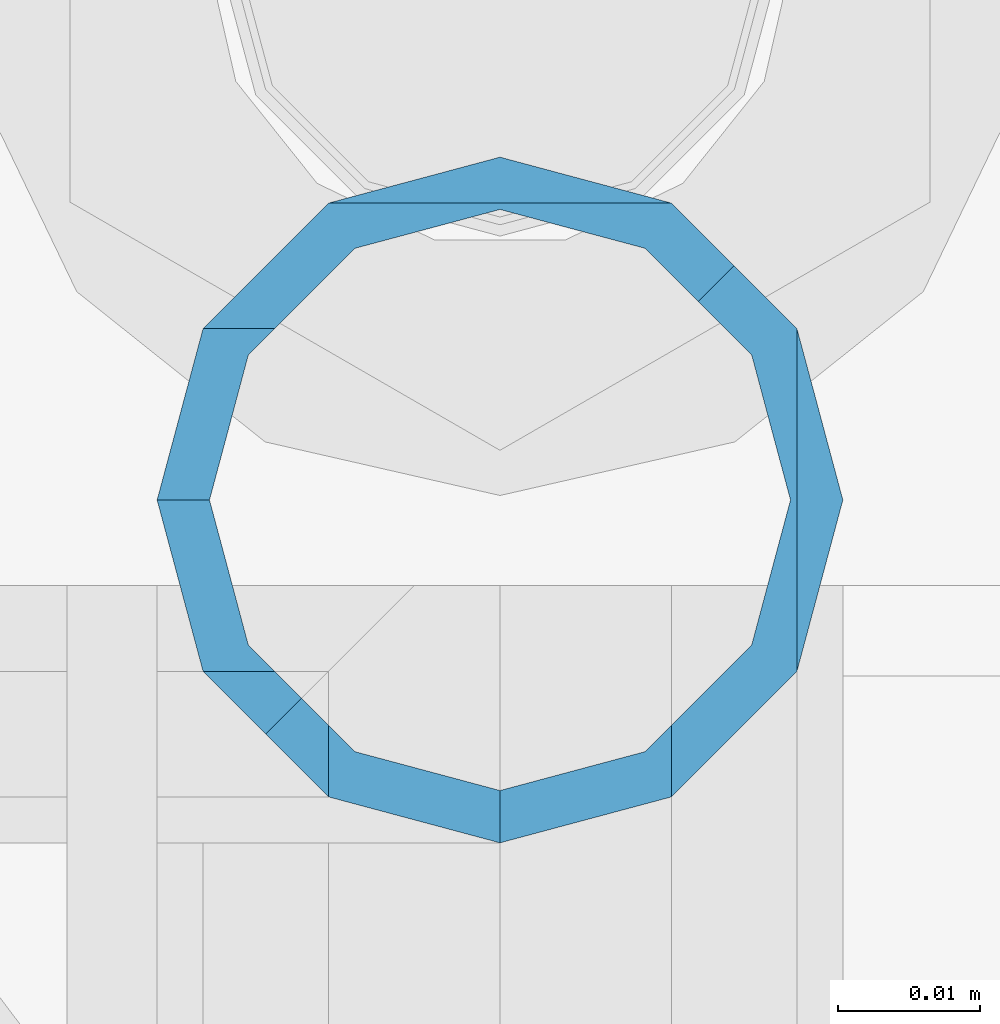
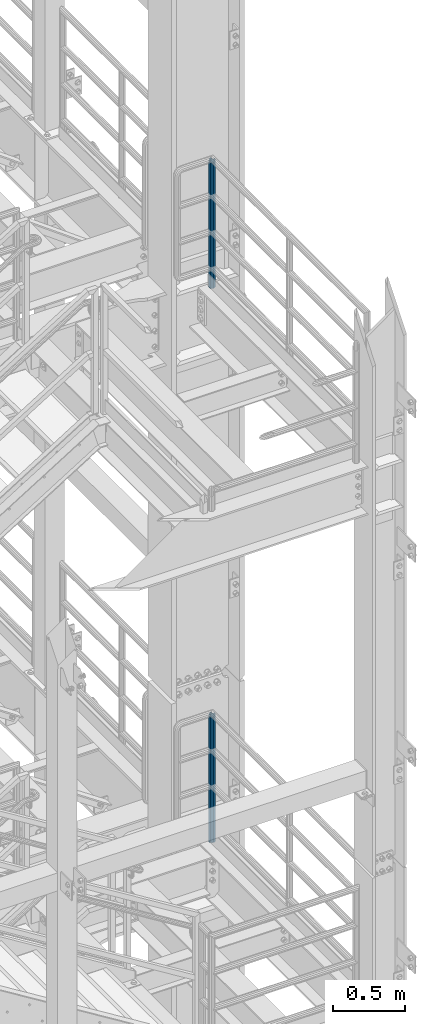
# One storey, part 664 of 1876: 2 columns, 2 elements without a shape of their own.
"""IFC2X3 building model written with IfcOpenShell, lengths in millimetres."""

from ifc_helpers import new_model, si_unit, frame, origin_with_axes, place, context, subcontext, project, spatial, faceted_brep, material, type_object, element, aggregate, save


model = new_model("IFC2X3")

# Units and contexts
model_context = context("Model", 3, precision=1e-05, world=origin_with_axes())
body_context = subcontext(model_context, "Body", "Model", "MODEL_VIEW")
ifc_project = project(units=[si_unit("LENGTHUNIT", "METRE", prefix="MILLI"), si_unit("AREAUNIT", "SQUARE_METRE"), si_unit("VOLUMEUNIT", "CUBIC_METRE"), si_unit("MASSUNIT", "GRAM", prefix="KILO"), si_unit("TIMEUNIT", "SECOND"), si_unit("PLANEANGLEUNIT", "RADIAN"), si_unit("SOLIDANGLEUNIT", "STERADIAN"), si_unit("THERMODYNAMICTEMPERATUREUNIT", "DEGREE_CELSIUS"), si_unit("LUMINOUSINTENSITYUNIT", "LUMEN")], contexts=[model_context])

# Site, building, storey
site_placement = place(None, origin_with_axes())
site = spatial("IfcSite", under=ifc_project, at=site_placement, CompositionType="ELEMENT")
building_placement = place(site_placement, origin_with_axes())
building = spatial("IfcBuilding", under=site, at=building_placement, Name="Undefined", CompositionType="ELEMENT")
storey_placement = place(building_placement, origin_with_axes())
storey = spatial("IfcBuildingStorey", under=building, at=storey_placement, Name="Undefined", CompositionType="ELEMENT", Elevation=0.0)

# Assembly, column
assembly_1_placement = place(storey_placement, origin_with_axes())
assembly_1 = element("IfcElementAssembly", 1, at=assembly_1_placement, inside=storey, Name="RAIL", AssemblyPlace="NOTDEFINED", PredefinedType="RIGID_FRAME")
ifc_material = material()
column_type = type_object("IfcColumnType", Name="PIPE1-1/2SCH40", PredefinedType="NOTDEFINED")
column_1_placement = place(assembly_1_placement, frame((7620.00000000001, -4788.2175, 17983.2), z_axis=(0.0, 1.0, 0.0), x_axis=(0.0, 0.0, 1.0)))
column_1 = element("IfcColumn", 2, at=column_1_placement, type_object=column_type, material=ifc_material, Name="POST", ObjectType="PIPE1-1/2SCH40", context=body_context, shape_type="Brep", body=[
    faceted_brep([(1076.325, 24.1300000000001, 0.0), (1064.26, 20.8971929933184, 12.0649999999996), (1064.25999999999, 20.8971929933186, -12.0649999999996), (1059.84389372958, 16.4810867391689, 16.4811062541503), (1057.32835795224, 13.9655509593422, 13.9655704718371), (1061.07042843786, 17.7076214311803, 10.2235000000001), (1063.80980700668, 20.4469999999999, 0.0), (1061.07042843786, 17.7076214311803, -10.2235000000001), (1055.42780700668, 12.0650000000001, -15.8661214311805), (1055.42780700667, 12.0649999999996, -20.8971929933186), (1054.93437856882, 10.2235000000001, -17.7076214311801), (1052.195, 0.0, -20.4470000000001), (1052.19499999999, 0.0, -24.1300000000001), (1055.42780700668, -12.0650000000001, -15.8661214311805), (1055.42780700667, -12.0649999999996, -20.8971929933186), (1054.93437856882, -10.2235000000001, -17.7076214311801), (1057.32837749231, -13.9655704718352, -13.9655509593449), (1059.84391327711, -16.4811062541476, -16.4810867391716), (1055.42780700668, -15.8661214311742, -12.065000000006), (1055.42780700668, -20.8971929933184, -12.0649999999996), (1054.93437856882, -17.7076214311801, -10.2235000000001), (1052.195, -20.4470000000001, 0.0), (1052.195, -24.1300000000001, 0.0), (1054.93437856882, -17.7076214311801, 10.2235000000001), (1055.42780700668, -15.8661214311869, 12.0649999999932), (1055.42780700668, -20.8971929933184, 12.0649999999996), (1076.325, 0.0, 24.1300000000001), (1064.26, -12.0650000000001, 20.8971929933186), (1064.26, 12.065, 20.8971929933186), (1061.07042843787, -10.2235000000001, 17.7076214311801), (1063.80980700669, 0.0, 20.4470000000001), (1061.07042843787, 10.2235000000001, 17.7076214311801), (0.0, -20.8971929933184, -12.0649999999996), (0.0, -12.0650000000001, -20.8971929933186), (-1.45519152283669e-11, 0.0, -24.130000000001), (0.0, 12.0650000000001, -20.8971929933186), (0.0, 20.8971929933184, -12.0649999999996), (0.0, 24.1299999999992, 0.0), (0.0, 20.8971929933184, 12.0649999999996), (0.0, 12.0650000000001, 20.8971929933186), (-1.45519152283669e-11, 0.0, 24.130000000001), (0.0, -20.8971929933184, 12.0649999999996), (0.0, -24.1299999999992, 0.0), (0.0, -12.0650000000001, 20.8971929933186), (0.0, -17.7076214311803, -10.2235000000001), (0.0, -10.2235000000001, -17.7076214311801), (-1.45519152283669e-11, 0.0, -20.4470000000001), (0.0, 10.2235000000001, -17.7076214311801), (0.0, 17.7076214311803, -10.2235000000001), (0.0, 20.4469999999999, 0.0), (0.0, 17.7076214311803, 10.2235000000001), (0.0, 10.2235000000001, 17.7076214311801), (-1.45519152283669e-11, 0.0, 20.4470000000001), (0.0, -10.2235000000001, 17.7076214311801), (0.0, -17.7076214311803, 10.2235000000001), (0.0, -20.4469999999999, 0.0)], [[[0, 1, 2]], [[3, 4, 5, 6, 7, 8, 9, 2, 1]], [[10, 11, 12, 9, 8]], [[13, 14, 12, 11, 15]], [[14, 13, 16, 17]], [[17, 16, 18, 19]], [[19, 18, 20, 21, 22]], [[22, 21, 23, 24, 25]], [[26, 27, 28]], [[25, 24, 29, 30, 31, 4, 3, 28, 27]], [[32, 33, 14, 17, 19]], [[33, 34, 12, 14]], [[34, 35, 9, 12]], [[35, 36, 2, 9]], [[36, 37, 0, 2]], [[37, 38, 1, 0]], [[1, 38, 39, 28, 3]], [[39, 40, 26, 28]], [[41, 42, 22, 25]], [[43, 41, 25, 27]], [[40, 43, 27, 26]], [[42, 32, 19, 22]], [[41, 43, 40, 39, 38, 37, 36, 35, 34, 33, 32, 42], [44, 45, 46, 47, 48, 49, 50, 51, 52, 53, 54, 55]], [[53, 52, 30, 29]], [[23, 54, 53, 29, 24]], [[55, 54, 23, 21]], [[44, 55, 21, 20]], [[15, 45, 44, 20, 18, 16, 13]], [[46, 45, 15, 11]], [[47, 46, 11, 10]], [[48, 47, 10, 8, 7]], [[49, 48, 7, 6]], [[50, 49, 6, 5]], [[51, 50, 5, 4, 31]], [[52, 51, 31, 30]]]),
])
aggregate(assembly_1, [column_1])

assembly_2_placement = place(storey_placement, origin_with_axes())
assembly_2 = element("IfcElementAssembly", 3, at=assembly_2_placement, inside=storey, Name="RAIL", AssemblyPlace="NOTDEFINED", PredefinedType="RIGID_FRAME")
column_2_placement = place(assembly_2_placement, frame((7620.00000000001, -4788.2175, 13309.6), z_axis=(0.0, 1.0, 0.0), x_axis=(0.0, 0.0, 1.0)))
column_2 = element("IfcColumn", 4, at=column_2_placement, type_object=column_type, material=ifc_material, Name="POST", ObjectType="PIPE1-1/2SCH40", context=body_context, shape_type="Brep", body=[
    faceted_brep([(1076.325, 24.1300000000001, 0.0), (1064.26, 20.8971929933184, 12.0649999999996), (1064.25999999999, 20.8971929933186, -12.0649999999996), (1059.84389372958, 16.4810867391689, 16.4811062541503), (1057.32835795224, 13.9655509593422, 13.9655704718371), (1061.07042843786, 17.7076214311803, 10.2235000000001), (1063.80980700668, 20.4469999999999, 0.0), (1061.07042843786, 17.7076214311803, -10.2235000000001), (1055.42780700668, 12.0650000000001, -15.8661214311805), (1055.42780700667, 12.0649999999996, -20.8971929933186), (1054.93437856882, 10.2235000000001, -17.7076214311801), (1052.195, 0.0, -20.4470000000001), (1052.19499999999, 0.0, -24.1300000000001), (1055.42780700668, -12.0650000000001, -15.8661214311805), (1055.42780700667, -12.0649999999996, -20.8971929933186), (1054.93437856882, -10.2235000000001, -17.7076214311801), (1057.32837749231, -13.9655704718352, -13.9655509593449), (1059.84391327711, -16.4811062541476, -16.4810867391716), (1055.42780700668, -15.8661214311742, -12.065000000006), (1055.42780700668, -20.8971929933184, -12.0649999999996), (1054.93437856882, -17.7076214311801, -10.2235000000001), (1052.195, -20.4470000000001, 0.0), (1052.195, -24.1300000000001, 0.0), (1054.93437856882, -17.7076214311801, 10.2235000000001), (1055.42780700668, -15.8661214311869, 12.0649999999932), (1055.42780700668, -20.8971929933184, 12.0649999999996), (1076.325, 0.0, 24.1300000000001), (1064.26, -12.0650000000001, 20.8971929933186), (1064.26, 12.065, 20.8971929933186), (1061.07042843787, -10.2235000000001, 17.7076214311801), (1063.80980700669, 0.0, 20.4470000000001), (1061.07042843787, 10.2235000000001, 17.7076214311801), (0.0, -20.8971929933184, -12.0649999999996), (0.0, -12.0650000000001, -20.8971929933186), (-1.45519152283669e-11, 0.0, -24.130000000001), (0.0, 12.0650000000001, -20.8971929933186), (0.0, 20.8971929933184, -12.0649999999996), (0.0, 24.1299999999992, 0.0), (0.0, 20.8971929933184, 12.0649999999996), (0.0, 12.0650000000001, 20.8971929933186), (-1.45519152283669e-11, 0.0, 24.130000000001), (0.0, -20.8971929933184, 12.0649999999996), (0.0, -24.1299999999992, 0.0), (0.0, -12.0650000000001, 20.8971929933186), (0.0, -17.7076214311803, -10.2235000000001), (0.0, -10.2235000000001, -17.7076214311801), (-1.45519152283669e-11, 0.0, -20.4470000000001), (0.0, 10.2235000000001, -17.7076214311801), (0.0, 17.7076214311803, -10.2235000000001), (0.0, 20.4469999999999, 0.0), (0.0, 17.7076214311803, 10.2235000000001), (0.0, 10.2235000000001, 17.7076214311801), (-1.45519152283669e-11, 0.0, 20.4470000000001), (0.0, -10.2235000000001, 17.7076214311801), (0.0, -17.7076214311803, 10.2235000000001), (0.0, -20.4469999999999, 0.0)], [[[0, 1, 2]], [[3, 4, 5, 6, 7, 8, 9, 2, 1]], [[10, 11, 12, 9, 8]], [[13, 14, 12, 11, 15]], [[14, 13, 16, 17]], [[17, 16, 18, 19]], [[19, 18, 20, 21, 22]], [[22, 21, 23, 24, 25]], [[26, 27, 28]], [[25, 24, 29, 30, 31, 4, 3, 28, 27]], [[32, 33, 14, 17, 19]], [[33, 34, 12, 14]], [[34, 35, 9, 12]], [[35, 36, 2, 9]], [[36, 37, 0, 2]], [[37, 38, 1, 0]], [[1, 38, 39, 28, 3]], [[39, 40, 26, 28]], [[41, 42, 22, 25]], [[43, 41, 25, 27]], [[40, 43, 27, 26]], [[42, 32, 19, 22]], [[41, 43, 40, 39, 38, 37, 36, 35, 34, 33, 32, 42], [44, 45, 46, 47, 48, 49, 50, 51, 52, 53, 54, 55]], [[53, 52, 30, 29]], [[23, 54, 53, 29, 24]], [[55, 54, 23, 21]], [[44, 55, 21, 20]], [[15, 45, 44, 20, 18, 16, 13]], [[46, 45, 15, 11]], [[47, 46, 11, 10]], [[48, 47, 10, 8, 7]], [[49, 48, 7, 6]], [[50, 49, 6, 5]], [[51, 50, 5, 4, 31]], [[52, 51, 31, 30]]]),
])
aggregate(assembly_2, [column_2])

save(model, "model.ifc")
